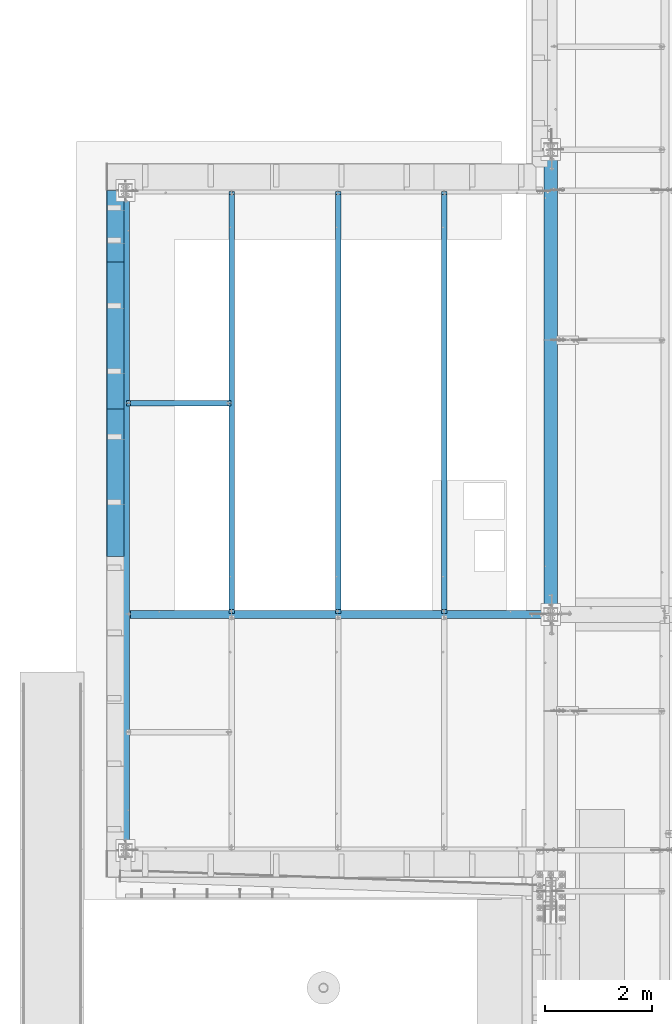
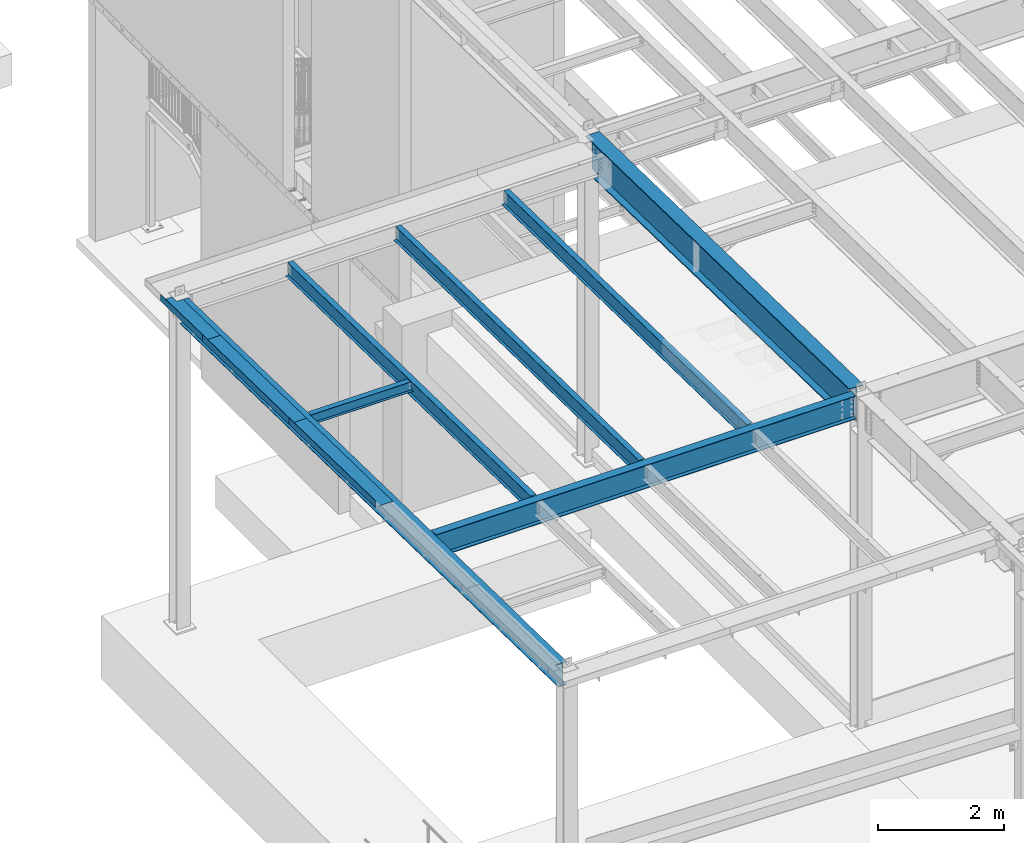
# One storey, part 1070 of 1763: 10 beams, 7 elements without a shape of their own.
"""IFC2X3 building model written with IfcOpenShell, lengths in millimetres."""

from ifc_helpers import new_model, si_unit, frame, origin_with_axes, place, context, subcontext, project, spatial, faceted_brep, material, type_object, element, aggregate, save


model = new_model("IFC2X3")

# Units and contexts
model_context = context("Model", 3, precision=1e-05, world=origin_with_axes())
body_context = subcontext(model_context, "Body", "Model", "MODEL_VIEW")
ifc_project = project(units=[si_unit("LENGTHUNIT", "METRE", prefix="MILLI"), si_unit("AREAUNIT", "SQUARE_METRE"), si_unit("VOLUMEUNIT", "CUBIC_METRE"), si_unit("MASSUNIT", "GRAM", prefix="KILO"), si_unit("TIMEUNIT", "SECOND"), si_unit("PLANEANGLEUNIT", "RADIAN"), si_unit("SOLIDANGLEUNIT", "STERADIAN"), si_unit("THERMODYNAMICTEMPERATUREUNIT", "DEGREE_CELSIUS"), si_unit("LUMINOUSINTENSITYUNIT", "LUMEN")], contexts=[model_context])

# Site, building, storey
site_placement = place(None, origin_with_axes())
site = spatial("IfcSite", under=ifc_project, at=site_placement, CompositionType="ELEMENT")
building_placement = place(site_placement, origin_with_axes())
building = spatial("IfcBuilding", under=site, at=building_placement, Name="Undefined", CompositionType="ELEMENT")
storey_placement = place(building_placement, origin_with_axes())
storey = spatial("IfcBuildingStorey", under=building, at=storey_placement, Name="Undefined", CompositionType="ELEMENT", Elevation=0.0)

# Assembly, beam
assembly_1_placement = place(storey_placement, origin_with_axes())
assembly_1 = element("IfcElementAssembly", 1, at=assembly_1_placement, inside=storey, Name="BEAM", AssemblyPlace="NOTDEFINED", PredefinedType="RIGID_FRAME")
ifc_material_1 = material(Name="STEEL/A992")
beam_type_1 = type_object("IfcBeamType", Name="W8X10", PredefinedType="NOTDEFINED")
beam_1_placement = place(assembly_1_placement, frame((-95300.2372736984, 17627.6, 11454.7309010969), z_axis=(0.0, 0.0, 1.0), x_axis=(1.0, 0.0, 0.0)))
beam_1 = element("IfcBeam", 2, at=beam_1_placement, type_object=beam_type_1, material=ifc_material_1, Name="BEAM", ObjectType="W8X10", context=body_context, shape_type="Brep", body=[
    faceted_brep([(1915.31874999999, -50.7999999999993, 100.012500000001), (1915.31874999999, -50.7999999999993, 95.25), (1915.31874999999, -2.38125000000036, 95.25), (1915.31874999999, -2.38125000000036, 87.0525014892301), (1915.31874999999, 2.38125000000036, 87.0525014892301), (1915.31874999999, 2.38125000000036, 95.25), (1915.31874999999, 50.7999999999993, 95.25), (1915.31874999999, 50.7999999999993, 100.012500000001), (1916.28547992258, -2.38125000000036, 82.1924219711836), (1916.28547992258, 2.38125000000036, 82.1924219711836), (1919.03849382306, -2.38125000000036, 78.07224550303), (1919.03849382306, 2.38125000000036, 78.07224550303), (1923.15867029122, -2.38125000000036, 75.3192316025525), (1923.15867029122, 2.38125000000036, 75.3192316025525), (1928.01874980926, -2.38125000000036, 74.3525016799649), (1928.01874980926, 2.38125000000036, 74.3525016799649), (1966.11874999999, -2.38125000000036, 74.3525016799649), (1966.11874999999, 2.38125000000036, 74.3525016799649), (92.8687499999942, -50.7999999999993, 100.012500000001), (92.8687499999942, 50.7999999999993, 100.012500000001), (92.8687499999942, 50.7999999999993, 95.25), (92.8687499999942, 2.38125000000036, 95.25), (92.8687499999942, 2.38125000000036, 80.7025014877545), (92.8687499999942, -2.38125000000036, 80.7025014877545), (92.8687499999942, -2.38125000000036, 95.25), (92.8687499999942, -50.7999999999993, 95.25), (91.9020200774103, 2.38125000000036, 75.8424219697081), (91.9020200774103, -2.38125000000036, 75.8424219697081), (89.1490061769291, 2.38125000000036, 71.7222455015544), (89.1490061769291, -2.38125000000036, 71.7222455015544), (85.0288297087682, 2.38125000000036, 68.9692316010769), (85.0288297087682, -2.38125000000036, 68.9692316010769), (80.168750190729, 2.38125000000036, 68.0025016784894), (80.168750190729, -2.38125000000036, 68.0025016784894), (16.6687499999971, 2.38125000000036, 68.0025016784894), (16.6687499999971, -2.38125000000036, 68.0025016784894), (16.6687500075204, 2.38124999999854, -95.25), (16.6687500075204, 50.8000000000029, -95.25), (16.6687500075204, 50.8000000000029, -100.012500000001), (16.6687500075204, -50.8000000000029, -100.012500000001), (16.6687500075204, -50.8000000000029, -95.25), (16.6687500075204, -2.38124999999854, -95.25), (1966.11874999999, 2.38125000000036, -95.25), (1966.11874999999, 50.7999999999993, -95.25), (1966.11874999999, 50.7999999999993, -100.012500000001), (1966.11874999999, -50.7999999999993, -100.012500000001), (1966.11874999999, -50.7999999999993, -95.25), (1966.11874999999, -2.38125000000036, -95.25)], [[[0, 1, 2, 3, 4, 5, 6, 7]], [[8, 9, 4, 3]], [[10, 11, 9, 8]], [[12, 13, 11, 10]], [[14, 15, 13, 12]], [[16, 17, 15, 14]], [[18, 19, 20, 21, 22, 23, 24, 25]], [[23, 22, 26, 27]], [[27, 26, 28, 29]], [[29, 28, 30, 31]], [[31, 30, 32, 33]], [[33, 32, 34, 35]], [[36, 37, 38, 39, 40, 41, 35, 34]], [[37, 36, 42, 43]], [[38, 37, 43, 44]], [[39, 38, 44, 45]], [[40, 39, 45, 46]], [[41, 40, 46, 47]], [[27, 29, 31, 33, 35, 41, 47, 16, 14, 12, 10, 8, 3, 2, 24, 23]], [[2, 1, 25, 24]], [[1, 0, 18, 25]], [[0, 7, 19, 18]], [[7, 6, 20, 19]], [[6, 5, 21, 20]], [[5, 4, 9, 11, 13, 15, 17, 42, 36, 34, 32, 30, 28, 26, 22, 21]], [[47, 46, 45, 44, 43, 42, 17, 16]]]),
])
aggregate(assembly_1, [beam_1])

# Assembly, beams
assembly_2_placement = place(storey_placement, origin_with_axes())
assembly_2 = element("IfcElementAssembly", 3, at=assembly_2_placement, inside=storey, Name="BEAM", AssemblyPlace="NOTDEFINED", PredefinedType="RIGID_FRAME")
ifc_material_2 = material(Name="STEEL/A36")
beam_type_2 = type_object("IfcBeamType", PredefinedType="NOTDEFINED")
beam_2_placement = place(assembly_2_placement, frame((-95325.6372736983, 20926.7108025747, 11493.9865622908), z_axis=(0.0, -0.999802459002039, 0.0198756880000585), x_axis=(-1.0, 0.0, 0.0)))
beam_2 = element("IfcBeam", 4, at=beam_2_placement, type_object=beam_type_2, material=ifc_material_2, Name="BENT_PLATE", context=body_context, shape_type="Brep", body=[
    faceted_brep([(114.300418710671, -3.17499999876418, -523.755961264746), (114.299850901851, 3.175000001238, -523.755961263756), (114.29985188799, 3.17500000122527, -666.068000000174), (114.30041969681, -3.17499999877691, -666.068000000185), (-1.60071067512035e-10, -3.1750000000502, -523.755765972852), (-2.3283064365387e-10, 3.1749999999538, -523.755765971866), (323.849975583202, 3.17500000369728, 666.06800000001), (2.18278728425503e-10, 3.17500000005748, 666.068000000134), (2.91038304567337e-10, -3.17499999994652, 666.068000000123), (317.49997558321, -3.17499999637585, 666.067999999999), (317.499975582527, -123.825002252635, 666.067999999668), (323.849975582518, -123.825002252635, 666.067999999668), (323.849975581383, 3.17500000357904, -666.068000000254), (323.849975582067, -123.825002251446, -666.068000000592), (317.499975582075, -123.825002251446, -666.068000000592), (317.499975581391, -3.17499999649226, -666.068000000261)], [[[0, 1, 2, 3]], [[4, 5, 1, 0]], [[6, 7, 8, 9, 10, 11]], [[12, 6, 11, 13]], [[10, 14, 13, 11]], [[9, 15, 14, 10]], [[12, 13, 14, 15, 3, 2]], [[7, 6, 12, 2, 1, 5]], [[8, 7, 5, 4]], [[15, 9, 8, 4, 0, 3]]]),
])
beam_3_placement = place(assembly_2_placement, frame((-95325.6372736983, 18889.4453255444, 11534.4866157075), z_axis=(0.0, -0.999802459002039, 0.0198756880000585), x_axis=(-1.0, 0.0, 0.0)))
beam_3 = element("IfcBeam", 5, at=beam_3_placement, type_object=beam_type_2, material=ifc_material_2, Name="BENT_PLATE", context=body_context, shape_type="Brep", body=[
    faceted_brep([(2.91038304567337e-11, -3.17499999963729, -1371.60000000396), (-2.91038304567337e-11, -3.17500000036489, 1371.60000000395), (-2.91038304567337e-11, 3.17499999963184, 1371.60000000395), (2.91038304567337e-11, 3.17500000035943, -1371.60000000396), (323.849975585938, 3.17500000012114, 1371.60000000027), (323.849975585938, 3.17499999988104, -1371.60000000028), (317.499975585932, -3.17500000012114, -1371.60000000027), (317.499975585932, -3.17499999988286, 1371.60000000027), (323.849975585938, -123.825002256748, 1371.60000000028), (323.849975585938, -123.825002256988, -1371.60000000026), (317.500000000218, -123.824997303656, 1371.60000000394), (317.500000000218, -123.824997303087, -1371.60000000397)], [[[0, 1, 2, 3]], [[3, 2, 4, 5]], [[1, 0, 6, 7]], [[5, 4, 8, 9]], [[4, 2, 1, 7, 10, 8]], [[7, 6, 11, 10]], [[6, 0, 3, 5, 9, 11]], [[10, 11, 9, 8]]]),
])
beam_4_placement = place(assembly_2_placement, frame((-95325.6372736983, 16146.7872200094, 11589.0096030265), z_axis=(0.0, -0.999802459002039, 0.0198756880000585), x_axis=(-1.0, 0.0, 0.0)))
beam_4 = element("IfcBeam", 6, at=beam_4_placement, type_object=beam_type_2, material=ifc_material_2, Name="BENT_PLATE", context=body_context, shape_type="Brep", body=[
    faceted_brep([(2.91038304567337e-11, -3.17499999963729, -1371.60000000396), (-2.91038304567337e-11, -3.17500000036489, 1371.60000000395), (-2.91038304567337e-11, 3.17499999963184, 1371.60000000395), (2.91038304567337e-11, 3.17500000035943, -1371.60000000396), (323.849975585938, 3.17500000012114, 1371.60000000027), (323.849975585938, 3.17499999988104, -1371.60000000028), (317.499975585932, -3.17500000012114, -1371.60000000027), (317.499975585932, -3.17499999988286, 1371.60000000027), (323.849975585938, -123.825002256748, 1371.60000000028), (323.849975585938, -123.825002256988, -1371.60000000026), (317.500000000218, -123.824997303656, 1371.60000000394), (317.500000000218, -123.824997303087, -1371.60000000397)], [[[0, 1, 2, 3]], [[3, 2, 4, 5]], [[1, 0, 6, 7]], [[5, 4, 8, 9]], [[4, 2, 1, 7, 10, 8]], [[7, 6, 11, 10]], [[6, 0, 3, 5, 9, 11]], [[10, 11, 9, 8]]]),
])

# Assembly, beam
assembly_3_placement = place(storey_placement, origin_with_axes())
assembly_3 = element("IfcElementAssembly", 7, at=assembly_3_placement, inside=storey, Name="BEAM", AssemblyPlace="NOTDEFINED", PredefinedType="RIGID_FRAME")
beam_type_3 = type_object("IfcBeamType", Name="W18X35", PredefinedType="NOTDEFINED")
beam_5_placement = place(assembly_3_placement, frame((-95300.2372737046, 13690.6, 11406.3367881089), z_axis=(0.0, 0.0, 1.0), x_axis=(1.0, 0.0, 0.0)))
beam_5 = element("IfcBeam", 8, at=beam_5_placement, type_object=beam_type_3, material=ifc_material_1, Name="BEAM", ObjectType="W18X35", context=body_context, shape_type="Brep", body=[
    faceted_brep([(80.1687501969573, -3.96875, 193.415001678908), (80.1687501969573, 3.96875, 193.415001678908), (16.6687500062253, 3.96875, 193.415001678908), (16.6687500062253, -3.96875, 193.415001678908), (85.0288297149964, -3.96875, 194.381731601496), (85.0288297149964, 3.96875, 194.381731601496), (89.1490061831573, -3.96875, 197.134745501973), (89.1490061831573, 3.96875, 197.134745501973), (91.9020200836385, -3.96875, 201.254921970127), (91.9020200836385, 3.96875, 201.254921970127), (92.8687500062224, -3.96875, 206.115001488173), (92.8687500062224, 3.96875, 206.115001488173), (92.8687500062224, -76.2000000000007, 225.424999999999), (92.8687500062224, 76.2000000000007, 225.424999999999), (92.8687500062224, 76.2000000000007, 214.3125), (92.8687500062224, 3.96875, 214.3125), (92.8687500062224, -3.96875, 214.3125), (92.8687500062224, -76.2000000000007, 214.3125), (16.6687500062253, -3.96875, -193.95429188595), (16.6687500062253, 3.96875, -193.95429188595), (76.1999971451878, 3.96875, -193.95429188595), (76.1999971451878, -3.96875, -193.95429188595), (81.0600766632269, 3.96875, -194.921021808537), (81.0600766632269, -3.96875, -194.921021808537), (85.1802531313879, 3.96875, -197.674035709015), (85.1802531313879, -3.96875, -197.674035709015), (87.933267031869, 3.96875, -201.794212177168), (87.933267031869, -3.96875, -201.794212177168), (88.8999969544529, 3.96875, -206.654291695215), (88.8999969544529, -3.96875, -206.654291695215), (7785.10000000623, 3.96875, -214.3125), (7785.10000000623, 76.2000000000007, -214.3125), (88.8999969544529, 76.2000000000007, -214.3125), (88.8999969544529, 3.96875, -214.3125), (7785.10000000623, 76.2000000000007, -225.424999999999), (7785.10000000623, -76.2000000000007, -225.424999999999), (88.8999969544529, -76.2000000000007, -225.424999999999), (88.8999969544529, 76.2000000000007, -225.424999999999), (7785.10000000623, -76.2000000000007, -214.3125), (88.8999969544529, -76.2000000000007, -214.3125), (7785.10000000623, -3.96875, -214.3125), (88.8999969544529, -3.96875, -214.3125), (7785.10000000623, 3.96875, 214.3125), (7785.10000000623, 76.2000000000007, 214.3125), (7785.10000000623, 76.2000000000007, 225.424999999999), (7785.10000000623, -76.2000000000007, 225.424999999999), (7785.10000000623, -76.2000000000007, 214.3125), (7785.10000000623, -3.96875, 214.3125)], [[[0, 1, 2, 3]], [[4, 5, 1, 0]], [[6, 7, 5, 4]], [[8, 9, 7, 6]], [[10, 11, 9, 8]], [[12, 13, 14, 15, 11, 10, 16, 17]], [[18, 19, 20, 21]], [[21, 20, 22, 23]], [[23, 22, 24, 25]], [[25, 24, 26, 27]], [[27, 26, 28, 29]], [[30, 31, 32, 33]], [[34, 35, 36, 37]], [[35, 38, 39, 36]], [[38, 40, 41, 39]], [[29, 28, 33, 32, 37, 36, 39, 41]], [[31, 34, 37, 32]], [[30, 42, 43, 44, 45, 46, 47, 40, 38, 35, 34, 31]], [[46, 45, 12, 17]], [[47, 46, 17, 16]], [[8, 6, 4, 0, 3, 18, 21, 23, 25, 27, 29, 41, 40, 47, 16, 10]], [[19, 18, 3, 2]], [[42, 30, 33, 28, 26, 24, 22, 20, 19, 2, 1, 5, 7, 9, 11, 15]], [[43, 42, 15, 14]], [[44, 43, 14, 13]], [[45, 44, 13, 12]]]),
])
aggregate(assembly_3, [beam_5])

# Beam
beam_6_placement = place(assembly_2_placement, frame((-95300.2372736984, 9291.91952306493, 11496.63656719), z_axis=(0.0, 0.0198756880000401, 0.99980245900204), x_axis=(0.0, 0.999802459002039, -0.0198756880000571)))
beam_6 = element("IfcBeam", 9, at=beam_6_placement, type_object=beam_type_3, material=ifc_material_1, Name="BEAM", ObjectType="W18X35", context=body_context, shape_type="Brep", body=[
    faceted_brep([(148.690326337995, -76.1999999999971, -225.425000000028), (148.690326337995, 76.1999999999971, -225.425000000028), (12165.2640923165, 76.1999999999971, -225.42499999897), (12165.2640923165, -76.1999999999971, -225.42499999897), (148.469414115872, -76.1999999999971, -214.312500000025), (148.469414115872, -3.96875, -214.312500000025), (139.948514119764, -3.96875, 214.312500000058), (139.948514119764, -76.1999999999971, 214.312500000058), (139.727601897643, -76.1999999999971, 225.425000000061), (139.727601897643, 76.1999999999971, 225.425000000061), (139.948514119764, 76.1999999999971, 214.312500000058), (139.948514119764, 3.96875, 214.312500000058), (148.469414115872, 3.96875, -214.312500000025), (148.469414115872, 76.1999999999971, -214.312500000025), (12165.0431800944, -76.1999999999971, -214.312499998969), (12165.0431800944, -3.96875, -214.312499998969), (12156.5222800983, -3.96875, 214.312500001117), (12156.5222800983, -76.1999999999971, 214.312500001117), (12156.3013678762, -76.1999999999971, 225.42500000112), (12156.3013678762, 76.1999999999971, 225.42500000112), (12156.5222800983, 76.1999999999971, 214.312500001117), (12156.5222800983, 3.96875, 214.312500001117), (12165.0431800944, 3.96875, -214.312499998969), (12165.0431800944, 76.1999999999971, -214.312499998969)], [[[0, 1, 2, 3]], [[0, 4, 5, 6, 7, 8, 9, 10, 11, 12, 13, 1]], [[5, 4, 14, 15]], [[6, 5, 15, 16]], [[7, 6, 16, 17]], [[8, 7, 17, 18]], [[9, 8, 18, 19]], [[10, 9, 19, 20]], [[11, 10, 20, 21]], [[12, 11, 21, 22]], [[13, 12, 22, 23]], [[1, 13, 23, 2]], [[22, 21, 20, 19, 18, 17, 16, 15, 14, 3, 2, 23]], [[4, 0, 3, 14]]]),
])

aggregate(assembly_2, [beam_2, beam_3, beam_4, beam_6])

# Assembly, beam
assembly_4_placement = place(storey_placement, origin_with_axes())
assembly_4 = element("IfcElementAssembly", 10, at=assembly_4_placement, inside=storey, Name="BEAM", AssemblyPlace="NOTDEFINED", PredefinedType="RIGID_FRAME")
beam_type_4 = type_object("IfcBeamType", Name="W12X14", PredefinedType="NOTDEFINED")
beam_7_placement = place(assembly_4_placement, frame((-89356.6372736983, 13687.6502634704, 11480.9781370654), z_axis=(0.0, 0.0195589670021127, 0.999808705108037), x_axis=(0.0, 0.999808705108038, -0.0195589670020975)))
beam_7 = element("IfcBeam", 11, at=beam_7_placement, type_object=beam_type_4, material=ifc_material_1, Name="BEAM", ObjectType="W12X14", context=body_context, shape_type="Brep", body=[
    faceted_brep([(83.1222403501033, -2.38125000000582, 118.802501678494), (83.1222403501033, 2.38125000000582, 118.802501678494), (17.2981413610232, 2.38125000000582, 118.802501678489), (17.2981413610232, -2.38125000000582, 118.802501678489), (87.9823198681497, -2.38125000000582, 119.769231601085), (87.9823198681497, 2.38125000000582, 119.769231601085), (92.1024963363034, -2.38125000000582, 122.522245501563), (92.1024963363034, 2.38125000000582, 122.522245501563), (94.8555102367827, -2.38125000000582, 126.642421969718), (94.8555102367827, 2.38125000000582, 126.642421969718), (95.8222401593684, -2.38125000000582, 131.502501487766), (95.8222401593684, 2.38125000000582, 131.502501487766), (95.8222401593648, -50.8000000000029, 150.812500000018), (95.8222401593648, 50.8000000000029, 150.812500000018), (95.8222401593666, 50.8000000000029, 144.462500000018), (95.8222401593666, 2.38125000000582, 144.462500000018), (95.8222401593666, -2.38125000000582, 144.462500000018), (95.8222401593666, -50.8000000000029, 144.462500000018), (22.4483180441548, -2.38125000000582, -144.462500000003), (22.4483180441548, -50.8000000000029, -144.462500000003), (7890.80974539851, -50.8000000000029, -144.462499999201), (7890.80974539851, -2.38125000000582, -144.462499999201), (22.5725412478823, -50.8000000000029, -150.812500000004), (7890.93396860224, -50.8000000000029, -150.812499999201), (22.5725412478823, 50.8000000000029, -150.812500000004), (7890.93396860224, 50.8000000000029, -150.812499999201), (22.4483180441548, 50.8000000000029, -144.462500000003), (7890.80974539851, 50.8000000000029, -144.462499999201), (22.4483180441548, 2.38125000000582, -144.462500000003), (7890.80974539851, 2.38125000000582, -144.462499999201), (7885.65956871517, 2.38125000000582, 118.802501690212), (7885.65956871517, -2.38125000000582, 118.802501690212), (7837.1836673238, 2.38125000000582, 118.802501690296), (7837.1836673238, -2.38125000000582, 118.802501690296), (7832.32358780576, 2.38125000000582, 119.769231612887), (7832.32358780576, -2.38125000000582, 119.769231612887), (7828.20341133761, 2.38125000000582, 122.52224551337), (7828.20341133761, -2.38125000000582, 122.52224551337), (7825.45039743715, 2.38125000000582, 126.642421981533), (7825.45039743715, -2.38125000000582, 126.642421981533), (7824.48366751458, 2.38125000000582, 131.502501499584), (7824.48366751458, -2.38125000000582, 131.502501499584), (7824.69682740927, -50.8000000000029, 150.812500000804), (7824.48366751465, -50.8000000000029, 144.462500000804), (7824.48366751465, -2.38125000000582, 144.462500000804), (7824.48366751465, 2.38125000000582, 144.462500000804), (7824.48366751465, 50.8000000000029, 144.462500000804), (7824.69682740927, 50.8000000000029, 150.812500000804)], [[[0, 1, 2, 3]], [[4, 5, 1, 0]], [[6, 7, 5, 4]], [[8, 9, 7, 6]], [[10, 11, 9, 8]], [[12, 13, 14, 15, 11, 10, 16, 17]], [[18, 19, 20, 21]], [[19, 22, 23, 20]], [[22, 24, 25, 23]], [[24, 26, 27, 25]], [[26, 28, 29, 27]], [[21, 20, 23, 25, 27, 29, 30, 31]], [[31, 30, 32, 33]], [[33, 32, 34, 35]], [[35, 34, 36, 37]], [[37, 36, 38, 39]], [[39, 38, 40, 41]], [[42, 43, 44, 41, 40, 45, 46, 47]], [[43, 42, 12, 17]], [[44, 43, 17, 16]], [[8, 6, 4, 0, 3, 18, 21, 31, 33, 35, 37, 39, 41, 44, 16, 10]], [[28, 26, 24, 22, 19, 18, 3, 2]], [[45, 40, 38, 36, 34, 32, 30, 29, 28, 2, 1, 5, 7, 9, 11, 15]], [[46, 45, 15, 14]], [[47, 46, 14, 13]], [[42, 47, 13, 12]]]),
])
aggregate(assembly_4, [beam_7])

assembly_5_placement = place(storey_placement, origin_with_axes())
assembly_5 = element("IfcElementAssembly", 12, at=assembly_5_placement, inside=storey, Name="BEAM", AssemblyPlace="NOTDEFINED", PredefinedType="RIGID_FRAME")
beam_8_placement = place(assembly_5_placement, frame((-91337.8372736984, 13687.6502634704, 11480.9781370654), z_axis=(0.0, 0.0195589670021127, 0.999808705108037), x_axis=(0.0, 0.999808705108038, -0.0195589670020975)))
beam_8 = element("IfcBeam", 13, at=beam_8_placement, type_object=beam_type_4, material=ifc_material_1, Name="BEAM", ObjectType="W12X14", context=body_context, shape_type="Brep", body=[
    faceted_brep([(7824.69682740927, -50.8000000000029, 150.812500000804), (7824.48366751465, -50.8000000000029, 144.462500000804), (7824.48366751465, -2.38125000000582, 144.462500000804), (7824.48366751458, -2.38125000000582, 131.502501499584), (7824.48366751458, 2.38125000000582, 131.502501499584), (7824.48366751465, 2.38125000000582, 144.462500000804), (7824.48366751465, 50.8000000000029, 144.462500000804), (7824.69682740927, 50.8000000000029, 150.812500000804), (7825.45039743715, -2.38125000000582, 126.642421981533), (7825.45039743715, 2.38125000000582, 126.642421981533), (7828.20341133761, -2.38125000000582, 122.52224551337), (7828.20341133761, 2.38125000000582, 122.52224551337), (7832.32358780576, -2.38125000000582, 119.769231612887), (7832.32358780576, 2.38125000000582, 119.769231612887), (7837.1836673238, -2.38125000000582, 118.802501690296), (7837.1836673238, 2.38125000000582, 118.802501690296), (7885.65956871517, -2.38125000000582, 118.802501690212), (7885.65956871517, 2.38125000000582, 118.802501690212), (95.8222401593648, -50.8000000000029, 150.812500000018), (95.8222401593648, 50.8000000000029, 150.812500000018), (95.8222401593666, 50.8000000000029, 144.462500000018), (95.8222401593666, 2.38125000000582, 144.462500000018), (95.8222401593684, 2.38125000000582, 131.502501487766), (95.8222401593684, -2.38125000000582, 131.502501487766), (95.8222401593666, -2.38125000000582, 144.462500000018), (95.8222401593666, -50.8000000000029, 144.462500000018), (94.8555102367827, 2.38125000000582, 126.642421969718), (94.8555102367827, -2.38125000000582, 126.642421969718), (92.1024963363034, 2.38125000000582, 122.522245501563), (92.1024963363034, -2.38125000000582, 122.522245501563), (87.9823198681497, 2.38125000000582, 119.769231601085), (87.9823198681497, -2.38125000000582, 119.769231601085), (83.1222403501033, 2.38125000000582, 118.802501678494), (83.1222403501033, -2.38125000000582, 118.802501678494), (17.2981413610232, 2.38125000000582, 118.802501678489), (17.2981413610232, -2.38125000000582, 118.802501678489), (22.4483180441548, 2.38125000000582, -144.462500000003), (22.4483180441548, 50.8000000000029, -144.462500000003), (22.5725412478823, 50.8000000000029, -150.812500000004), (22.5725412478823, -50.8000000000029, -150.812500000004), (22.4483180441548, -50.8000000000029, -144.462500000003), (22.4483180441548, -2.38125000000582, -144.462500000003), (7890.80974539851, 2.38125000000582, -144.462499999201), (7890.80974539851, 50.8000000000029, -144.462499999201), (7890.93396860224, 50.8000000000029, -150.812499999201), (7890.93396860224, -50.8000000000029, -150.812499999201), (7890.80974539851, -50.8000000000029, -144.462499999201), (7890.80974539851, -2.38125000000582, -144.462499999201)], [[[0, 1, 2, 3, 4, 5, 6, 7]], [[8, 9, 4, 3]], [[10, 11, 9, 8]], [[12, 13, 11, 10]], [[14, 15, 13, 12]], [[16, 17, 15, 14]], [[18, 19, 20, 21, 22, 23, 24, 25]], [[23, 22, 26, 27]], [[27, 26, 28, 29]], [[29, 28, 30, 31]], [[31, 30, 32, 33]], [[33, 32, 34, 35]], [[36, 37, 38, 39, 40, 41, 35, 34]], [[37, 36, 42, 43]], [[38, 37, 43, 44]], [[39, 38, 44, 45]], [[40, 39, 45, 46]], [[41, 40, 46, 47]], [[27, 29, 31, 33, 35, 41, 47, 16, 14, 12, 10, 8, 3, 2, 24, 23]], [[2, 1, 25, 24]], [[1, 0, 18, 25]], [[0, 7, 19, 18]], [[7, 6, 20, 19]], [[6, 5, 21, 20]], [[5, 4, 9, 11, 13, 15, 17, 42, 36, 34, 32, 30, 28, 26, 22, 21]], [[47, 46, 45, 44, 43, 42, 17, 16]]]),
])
aggregate(assembly_5, [beam_8])

assembly_6_placement = place(storey_placement, origin_with_axes())
assembly_6 = element("IfcElementAssembly", 14, at=assembly_6_placement, inside=storey, Name="BEAM", AssemblyPlace="NOTDEFINED", PredefinedType="RIGID_FRAME")
beam_9_placement = place(assembly_6_placement, frame((-93319.0372736984, 13687.6502634704, 11480.9781370654), z_axis=(0.0, 0.0195589670021127, 0.999808705108037), x_axis=(0.0, 0.999808705108038, -0.0195589670020975)))
beam_9 = element("IfcBeam", 15, at=beam_9_placement, type_object=beam_type_4, material=ifc_material_1, Name="BEAM", ObjectType="W12X14", context=body_context, shape_type="Brep", body=[
    faceted_brep([(7824.69682740927, -50.8000000000029, 150.812500000804), (7824.48366751465, -50.8000000000029, 144.462500000804), (7824.48366751465, -2.38125000000582, 144.462500000804), (7824.48366751458, -2.38125000000582, 131.502501499584), (7824.48366751458, 2.38125000000582, 131.502501499584), (7824.48366751465, 2.38125000000582, 144.462500000804), (7824.48366751465, 50.8000000000029, 144.462500000804), (7824.69682740927, 50.8000000000029, 150.812500000804), (7825.45039743715, -2.38125000000582, 126.642421981533), (7825.45039743715, 2.38125000000582, 126.642421981533), (7828.20341133761, -2.38125000000582, 122.52224551337), (7828.20341133761, 2.38125000000582, 122.52224551337), (7832.32358780576, -2.38125000000582, 119.769231612887), (7832.32358780576, 2.38125000000582, 119.769231612887), (7837.1836673238, -2.38125000000582, 118.802501690296), (7837.1836673238, 2.38125000000582, 118.802501690296), (7885.65956871517, -2.38125000000582, 118.802501690212), (7885.65956871517, 2.38125000000582, 118.802501690212), (95.8222401593648, -50.8000000000029, 150.812500000018), (95.8222401593648, 50.8000000000029, 150.812500000018), (95.8222401593666, 50.8000000000029, 144.462500000018), (95.8222401593666, 2.38125000000582, 144.462500000018), (95.8222401593684, 2.38125000000582, 131.502501487766), (95.8222401593684, -2.38125000000582, 131.502501487766), (95.8222401593666, -2.38125000000582, 144.462500000018), (95.8222401593666, -50.8000000000029, 144.462500000018), (94.8555102367827, 2.38125000000582, 126.642421969718), (94.8555102367827, -2.38125000000582, 126.642421969718), (92.1024963363034, 2.38125000000582, 122.522245501563), (92.1024963363034, -2.38125000000582, 122.522245501563), (87.9823198681497, 2.38125000000582, 119.769231601085), (87.9823198681497, -2.38125000000582, 119.769231601085), (83.1222403501033, 2.38125000000582, 118.802501678494), (83.1222403501033, -2.38125000000582, 118.802501678494), (17.2981413610232, 2.38125000000582, 118.802501678489), (17.2981413610232, -2.38125000000582, 118.802501678489), (22.4483180441548, 2.38125000000582, -144.462500000003), (22.4483180441548, 50.8000000000029, -144.462500000003), (22.5725412478823, 50.8000000000029, -150.812500000004), (22.5725412478823, -50.8000000000029, -150.812500000004), (22.4483180441548, -50.8000000000029, -144.462500000003), (22.4483180441548, -2.38125000000582, -144.462500000003), (7890.80974539851, 2.38125000000582, -144.462499999201), (7890.80974539851, 50.8000000000029, -144.462499999201), (7890.93396860224, 50.8000000000029, -150.812499999201), (7890.93396860224, -50.8000000000029, -150.812499999201), (7890.80974539851, -50.8000000000029, -144.462499999201), (7890.80974539851, -2.38125000000582, -144.462499999201)], [[[0, 1, 2, 3, 4, 5, 6, 7]], [[8, 9, 4, 3]], [[10, 11, 9, 8]], [[12, 13, 11, 10]], [[14, 15, 13, 12]], [[16, 17, 15, 14]], [[18, 19, 20, 21, 22, 23, 24, 25]], [[23, 22, 26, 27]], [[27, 26, 28, 29]], [[29, 28, 30, 31]], [[31, 30, 32, 33]], [[33, 32, 34, 35]], [[36, 37, 38, 39, 40, 41, 35, 34]], [[37, 36, 42, 43]], [[38, 37, 43, 44]], [[39, 38, 44, 45]], [[40, 39, 45, 46]], [[41, 40, 46, 47]], [[27, 29, 31, 33, 35, 41, 47, 16, 14, 12, 10, 8, 3, 2, 24, 23]], [[2, 1, 25, 24]], [[1, 0, 18, 25]], [[0, 7, 19, 18]], [[7, 6, 20, 19]], [[6, 5, 21, 20]], [[5, 4, 9, 11, 13, 15, 17, 42, 36, 34, 32, 30, 28, 26, 22, 21]], [[47, 46, 45, 44, 43, 42, 17, 16]]]),
])
aggregate(assembly_6, [beam_9])

assembly_7_placement = place(storey_placement, origin_with_axes())
assembly_7 = element("IfcElementAssembly", 16, at=assembly_7_placement, inside=storey, Name="BEAM", AssemblyPlace="NOTDEFINED", PredefinedType="RIGID_FRAME")
beam_type_5 = type_object("IfcBeamType", Name="W27X94", PredefinedType="NOTDEFINED")
beam_10_placement = place(assembly_7_placement, frame((-87375.4372736983, 13683.4661054977, 11290.5017916453), z_axis=(0.0, 0.0209013539966291, 0.999781542838788), x_axis=(0.0, 0.999781542776098, -0.0209013569953182)))
beam_10 = element("IfcBeam", 17, at=beam_10_placement, type_object=beam_type_5, material=ifc_material_1, Name="BEAM", ObjectType="W27X94", context=body_context, shape_type="Brep", body=[
    faceted_brep([(153.603173783891, -6.65050389309181, -322.262499999861), (154.001431636958, -6.64982811828668, -341.312499999856), (426.266056034512, -6.64966394208022, -341.3124999997), (426.266056034925, -6.65033947680786, -322.262499999699), (426.266128606021, -127.0, -322.262499999701), (426.266128606034, -127.0, -341.312499999698), (140.128783088501, -6.35000000000582, 322.262500000037), (153.603173783891, -6.35000000000582, -322.262499999861), (8537.43468233835, -6.35000000000582, -322.262499994924), (8523.96029164295, -6.35000000000582, 322.26250000497), (140.128783088501, -127.0, 322.262500000037), (8523.96029164295, -127.0, 322.26250000497), (139.730525235434, -127.0, 341.312500000035), (8523.56203378989, -127.0, 341.312500004968), (139.730525235434, 127.0, 341.312500000035), (8523.56203378989, 127.0, 341.312500004968), (140.128783088501, 127.0, 322.262500000037), (8523.96029164295, 127.0, 322.26250000497), (140.128783088501, 6.35000000000582, 322.262500000037), (8523.96029164295, 6.35000000000582, 322.26250000497), (153.603173783891, 6.35000000000582, -322.262499999861), (8537.43468233835, 6.35000000000582, -322.262499994924), (8276.69740417538, 6.65033941368165, -322.262499995079), (8276.69740417577, 6.64966387730965, -341.312499995076), (8276.69733232578, 127.0, -341.312499995076), (8276.69733232577, 127.0, -322.26249999508), (426.265981450981, 127.0, -341.312499999698), (426.265981450966, 127.0, -322.262499999701), (426.266054021122, 6.650339222615, -341.312499999698), (426.266054021531, 6.64966368788737, -322.262499999699), (154.001431636958, 6.65017504710704, -341.312499999856), (153.603173783891, 6.64949927230191, -322.262499999861), (8537.43468233835, 6.6504950755625, -322.262499994924), (8537.83294019141, 6.64981977702701, -341.312499994923), (8537.43468233835, -6.6495080197783, -322.262499994924), (8537.83294019141, -6.65018331832835, -341.312499994923), (8276.69741215832, -6.64966367947636, -322.262499995079), (8276.6974121587, -6.65033921586291, -341.312499995076), (8276.69748400789, -127.0, -322.262499995079), (8276.69748400791, -127.0, -341.312499995078)], [[[0, 1, 2, 3]], [[4, 3, 2, 5]], [[6, 7, 8, 9]], [[10, 6, 9, 11]], [[12, 10, 11, 13]], [[14, 12, 13, 15]], [[16, 14, 15, 17]], [[18, 16, 17, 19]], [[20, 18, 19, 21]], [[22, 23, 24, 25]], [[25, 24, 26, 27]], [[27, 26, 28, 29]], [[29, 28, 30, 31]], [[20, 21, 32, 22, 25, 27, 29, 31]], [[33, 23, 22, 32]], [[21, 19, 17, 15, 13, 11, 9, 8, 34, 35, 33, 32]], [[35, 34, 36, 37]], [[38, 39, 37, 36]], [[39, 38, 4, 5]], [[1, 30, 28, 26, 24, 23, 33, 35, 37, 39, 5, 2]], [[7, 6, 10, 12, 14, 16, 18, 20, 31, 30, 1, 0]], [[38, 36, 34, 8, 7, 0, 3, 4]]]),
])
aggregate(assembly_7, [beam_10])

save(model, "model.ifc")
